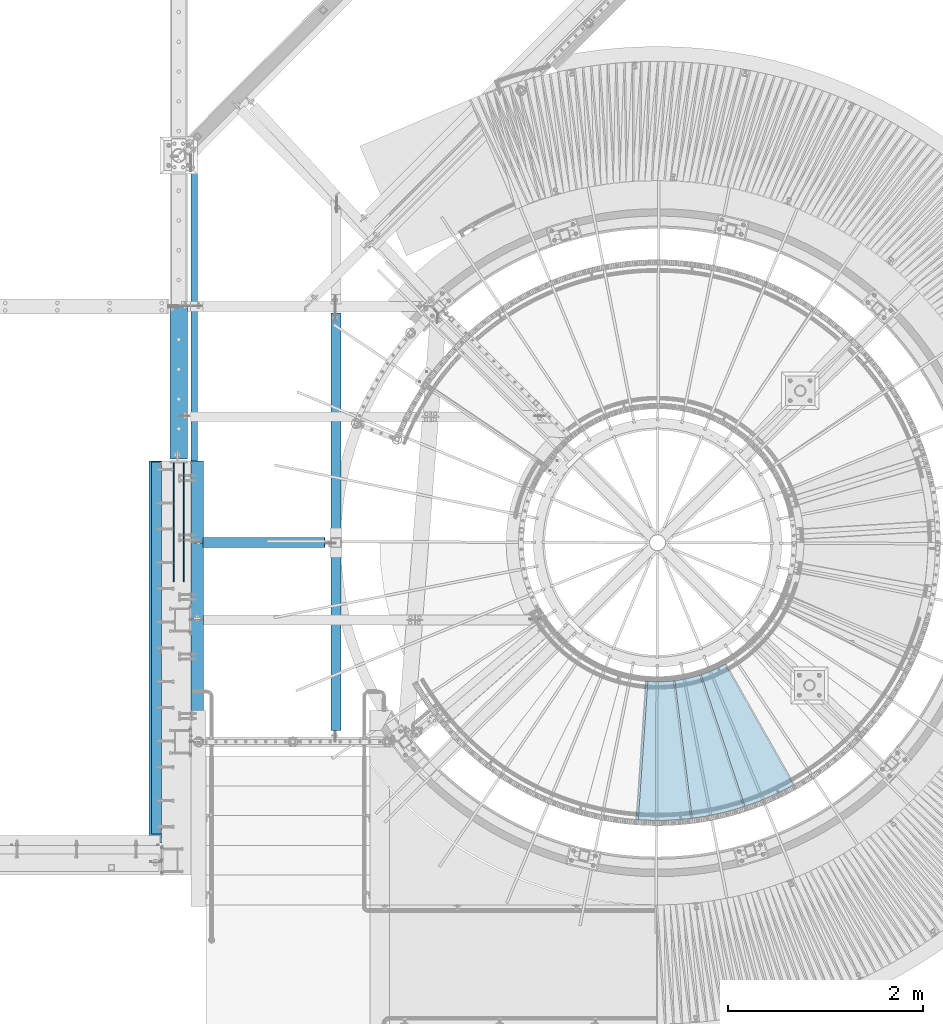
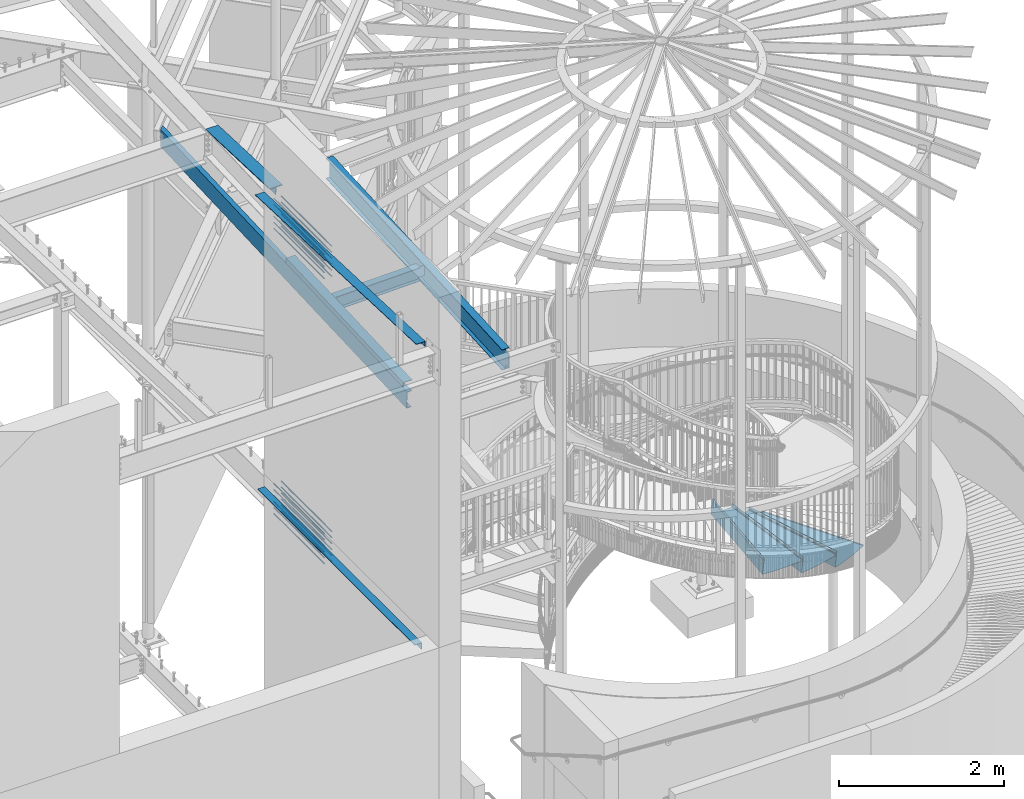
# One storey, part 341 of 975: 34 beams.
"""IFC2X3 building model written with IfcOpenShell, lengths in millimetres."""

from ifc_helpers import new_model, si_unit, frame, origin_with_axes, place, context, subcontext, project, spatial, faceted_brep, material, type_object, element, save


model = new_model("IFC2X3")

# Units and contexts
model_context = context("Model", 3, precision=1e-05, world=origin_with_axes())
body_context = subcontext(model_context, "Body", "Model", "MODEL_VIEW")
ifc_project = project(units=[si_unit("LENGTHUNIT", "METRE", prefix="MILLI"), si_unit("AREAUNIT", "SQUARE_METRE"), si_unit("VOLUMEUNIT", "CUBIC_METRE"), si_unit("MASSUNIT", "GRAM", prefix="KILO"), si_unit("TIMEUNIT", "SECOND"), si_unit("PLANEANGLEUNIT", "RADIAN"), si_unit("SOLIDANGLEUNIT", "STERADIAN"), si_unit("THERMODYNAMICTEMPERATUREUNIT", "DEGREE_CELSIUS"), si_unit("LUMINOUSINTENSITYUNIT", "LUMEN")], contexts=[model_context])

# Site, building, storey
site_placement = place(None, origin_with_axes())
site = spatial("IfcSite", under=ifc_project, at=site_placement, CompositionType="ELEMENT")
building_placement = place(site_placement, origin_with_axes())
building = spatial("IfcBuilding", under=site, at=building_placement, Name="Undefined", CompositionType="ELEMENT")
storey_placement = place(building_placement, origin_with_axes())
storey = spatial("IfcBuildingStorey", under=building, at=storey_placement, Name="Undefined", CompositionType="ELEMENT", Elevation=0.0)

# Beams
ifc_material_1 = material(Name="STEEL/A36")
beam_type_1 = type_object("IfcBeamType", Name="C10X15.3", PredefinedType="NOTDEFINED")
beam_1_placement = place(storey_placement, frame((29992.6373419842, 1312.79762171317, 6876.15207413472), z_axis=(-7.0905516622588e-09, -0.0430877640020049, 0.999071291046494), x_axis=(-8.50000000943246e-08, 0.999071290960394, 0.0430877659982918)))
element("IfcBeam", 1, at=beam_1_placement, inside=storey, type_object=beam_type_1, material=ifc_material_1, Name="BEAM", ObjectType="C10X15.3", context=body_context, shape_type="Brep", body=[
    faceted_brep([(-1.70985003933311e-10, -33.3375000000001, -126.999999999975), (-1.70985003933311e-10, 33.3375000000001, -126.999999999975), (5970.96165526552, 33.3374999961597, -127.000000000412), (6038.12023908904, -33.3375000038795, -127.0000000004), (-1.63709046319127e-10, -33.3375000000001, -121.44152749997), (6038.35996387556, -33.3375000038795, -121.441527500399), (-1.4915713109076e-10, 26.9875000000002, -111.391382499976), (5978.03087647182, 26.9874999961648, -111.391382500409), (1.52795109897852e-10, 26.9875000000002, 111.391382499978), (5978.10188780379, 26.9874999961648, -109.744850484867), (5978.68804457462, 26.9874999961685, -96.1536973187012), (5987.16476794745, 26.9874999962522, 100.395163735988), (5987.63901086143, 26.9874999962558, 111.391382499631), (1.70985003933311e-10, -33.3375000000001, 121.441527499974), (6048.83497990025, -33.3375000037777, 121.441527499643), (1.78260961547494e-10, -33.3375000000001, 126.999999999975), (6049.07470468678, -33.3375000037777, 126.999999999644), (1.78260961547494e-10, 33.3375000000001, 126.999999999975), (5981.91612086325, 33.3374999962653, 126.999999999633), (5981.25121124712, 33.337499996258, 111.582813192066), (5980.76871234526, 33.3374999962543, 100.395163737245), (5972.29198897244, 33.3374999961707, -96.1536973174443), (5971.71770683316, 33.337499996167, -109.469514695815)], [[[0, 1, 2, 3]], [[4, 0, 3, 5]], [[6, 4, 5, 7]], [[8, 6, 7, 9, 10, 11, 12]], [[13, 8, 12, 14]], [[15, 13, 14, 16]], [[0, 4, 6, 8, 13, 15, 17, 1]], [[1, 17, 18, 19, 20, 21, 22, 2]], [[21, 20, 19, 18, 16, 14, 12, 11, 10, 9, 7, 5, 3, 2, 22]], [[17, 15, 16, 18]]]),
])
beam_type_2 = type_object("IfcBeamType", PredefinedType="NOTDEFINED")
beam_2_placement = place(storey_placement, frame((35408.3134365946, 1319.64238191118, 3003.51695574218), z_axis=(0.314957553866778, -0.949105757680489, -2.58073669101578e-11), x_axis=(0.671119117250905, 0.222708622083281, 0.707106781264423)))
element("IfcBeam", 2, at=beam_2_placement, inside=storey, type_object=beam_type_2, material=ifc_material_1, Name="TREAD", context=body_context, shape_type="Brep", body=[
    faceted_brep([(25.4000001621371, 1.5874997143419, 653.28751700326), (1.61144271260127e-08, 1.58750000026703, 653.458911680114), (-1.96268956642598e-08, -1.58749999973588, 653.437487347819), (15.8745748038546, -1.5875001784334, 653.330368544412), (-120.373022221533, -103.76749224318, 653.560250726816), (-154.208562872085, -137.603032237963, 653.560249286144), (-49.0005534961238, -242.811041643061, 652.140399877677), (-46.7554894721361, -240.565977619684, 652.140399877557), (-149.718432901582, -137.603030988068, 653.529952160912), (-118.287540217565, -106.172138299769, 653.529952144057), (82.2634121742994, -374.075007349978, 638.193006315465), (84.508476198167, -371.829943326711, 638.193006315345), (212.601306559884, -504.412901568812, 612.134347567509), (214.846370562875, -502.167837565145, 612.134347570151), (261.055176792581, -530.596712595621, 601.111823144849), (259.197053542079, -528.103470062568, 601.754434690294), (248.701623596196, -536.023091227627, 602.134831213494), (248.362633442506, -540.174228440612, 601.571851715846), (250.921725105154, -538.24319290819, 601.479100122608), (25.4000001865188, 1.58749971376164, -768.618736200977), (-118.287540216395, -106.172138302336, -768.542582766611), (-149.718433278054, -137.603031368186, -768.542582749815), (-92.8426928760819, -194.478774201189, -768.783692225286), (-95.087756899542, -196.723838224048, -768.783692225159), (-154.208562871598, -137.603032235413, -768.533065523057), (-120.373022220361, -103.767492245748, -768.533065418116), (15.8745748282345, -1.58750017901184, -768.605275732323), (-1.58015609486029e-08, -1.58750000031432, -768.571627720263), (1.99397618416697e-08, 1.58749999968677, -768.564897939472), (-21.2434099455131, -266.078057151808, -776.330856581004), (-23.4884739689005, -268.323121174595, -776.330856580884), (49.7927349215133, -337.114201961485, -791.08236047571), (47.5476709198538, -339.35926596382, -791.082360478347), (66.437802308692, -335.979336534963, -793.502619428495), (56.3071310127107, -343.628597994977, -793.115412720523), (53.7487404151489, -345.560335457225, -793.01762786691), (54.0919957188744, -341.413461775162, -792.424099714608), (64.5845451579717, -333.490960101732, -792.825137753654)], [[[0, 1, 2, 3, 4, 5, 6, 7, 8, 9]], [[7, 6, 10, 11]], [[11, 10, 12, 13]], [[14, 15, 16, 13, 12, 17, 18]], [[19, 20, 21, 22, 23, 24, 25, 26, 27, 28]], [[29, 30, 23, 22]], [[31, 32, 30, 29]], [[33, 34, 35, 32, 31, 36, 37]], [[34, 33, 14, 18]], [[35, 34, 18, 17]], [[10, 6, 5, 24, 23, 30, 32, 35, 17, 12]], [[25, 24, 5, 4]], [[26, 25, 4, 3]], [[27, 26, 3, 2]], [[28, 27, 2, 1]], [[19, 28, 1, 0]], [[20, 19, 0, 9]], [[20, 9, 8, 21]], [[36, 31, 29, 22, 21, 8, 7, 11, 13, 16]], [[37, 36, 16, 15]], [[33, 37, 15, 14]]]),
])
beam_3_placement = place(storey_placement, frame((34992.0712427579, 1228.61472275559, 3181.31695574218), z_axis=(0.125233692150883, -0.992127271246113, 1.18870502774371e-10), x_axis=(0.701539921236418, 0.0885535930298356, 0.707106781238242)))
element("IfcBeam", 3, at=beam_3_placement, inside=storey, type_object=beam_type_2, material=ifc_material_1, Name="TREAD", context=body_context, shape_type="Brep", body=[
    faceted_brep([(25.4000001621371, 1.5874997143419, 653.28751700326), (1.61144271260127e-08, 1.58750000026703, 653.458911680114), (-1.96268956642598e-08, -1.58749999973588, 653.437487347819), (15.8745748038546, -1.5875001784334, 653.330368544412), (-120.373022221533, -103.76749224318, 653.560250726816), (-154.208562872085, -137.603032237963, 653.560249286144), (-49.0005534961238, -242.811041643061, 652.140399877677), (-46.7554894721361, -240.565977619684, 652.140399877557), (-149.718432901582, -137.603030988068, 653.529952160912), (-118.287540217565, -106.172138299769, 653.529952144057), (82.2634121742994, -374.075007349978, 638.193006315465), (84.508476198167, -371.829943326711, 638.193006315345), (212.601306559884, -504.412901568812, 612.134347567509), (214.846370562875, -502.167837565145, 612.134347570151), (261.055176792581, -530.596712595621, 601.111823144849), (259.197053542079, -528.103470062568, 601.754434690294), (248.701623596196, -536.023091227627, 602.134831213494), (248.362633442506, -540.174228440612, 601.571851715846), (250.921725105154, -538.24319290819, 601.479100122608), (25.4000001865188, 1.58749971376164, -768.618736200977), (-118.287540216395, -106.172138302336, -768.542582766611), (-149.718433278054, -137.603031368186, -768.542582749815), (-92.8426928760819, -194.478774201189, -768.783692225286), (-95.087756899542, -196.723838224048, -768.783692225159), (-154.208562871598, -137.603032235413, -768.533065523057), (-120.373022220361, -103.767492245748, -768.533065418116), (15.8745748282345, -1.58750017901184, -768.605275732323), (-1.58015609486029e-08, -1.58750000031432, -768.571627720263), (1.99397618416697e-08, 1.58749999968677, -768.564897939472), (-21.2434099455131, -266.078057151808, -776.330856581004), (-23.4884739689005, -268.323121174595, -776.330856580884), (49.7927349215133, -337.114201961485, -791.08236047571), (47.5476709198538, -339.35926596382, -791.082360478347), (66.437802308692, -335.979336534963, -793.502619428495), (56.3071310127107, -343.628597994977, -793.115412720523), (53.7487404151489, -345.560335457225, -793.01762786691), (54.0919957188744, -341.413461775162, -792.424099714608), (64.5845451579717, -333.490960101732, -792.825137753654)], [[[0, 1, 2, 3, 4, 5, 6, 7, 8, 9]], [[7, 6, 10, 11]], [[11, 10, 12, 13]], [[14, 15, 16, 13, 12, 17, 18]], [[19, 20, 21, 22, 23, 24, 25, 26, 27, 28]], [[29, 30, 23, 22]], [[31, 32, 30, 29]], [[33, 34, 35, 32, 31, 36, 37]], [[34, 33, 14, 18]], [[35, 34, 18, 17]], [[10, 6, 5, 24, 23, 30, 32, 35, 17, 12]], [[25, 24, 5, 4]], [[26, 25, 4, 3]], [[27, 26, 3, 2]], [[28, 27, 2, 1]], [[19, 28, 1, 0]], [[20, 19, 0, 9]], [[20, 9, 8, 21]], [[36, 31, 29, 22, 21, 8, 7, 11, 13, 16]], [[37, 36, 16, 15]], [[33, 37, 15, 14]]]),
])
beam_4_placement = place(storey_placement, frame((34566.0810090848, 1219.90154443776, 3359.11695574218), z_axis=(-0.0692297635944196, -0.997600741696126, 3.83573933504522e-10), x_axis=(0.705410249287495, -0.0489528350199457, 0.707106781288134)))
element("IfcBeam", 4, at=beam_4_placement, inside=storey, type_object=beam_type_2, material=ifc_material_1, Name="TREAD", context=body_context, shape_type="Brep", body=[
    faceted_brep([(25.4000001621371, 1.5874997143419, 653.28751700326), (1.61144271260127e-08, 1.58750000026703, 653.458911680114), (-1.96268956642598e-08, -1.58749999973588, 653.437487347819), (15.8745748038546, -1.5875001784334, 653.330368544412), (-120.373022221533, -103.76749224318, 653.560250726816), (-154.208562872085, -137.603032237963, 653.560249286144), (-49.0005534961238, -242.811041643061, 652.140399877677), (-46.7554894721361, -240.565977619684, 652.140399877557), (-149.718432901582, -137.603030988068, 653.529952160912), (-118.287540217565, -106.172138299769, 653.529952144057), (82.2634121742994, -374.075007349978, 638.193006315465), (84.508476198167, -371.829943326711, 638.193006315345), (212.601306559884, -504.412901568812, 612.134347567509), (214.846370562875, -502.167837565145, 612.134347570151), (261.055176792581, -530.596712595621, 601.111823144849), (259.197053542079, -528.103470062568, 601.754434690294), (248.701623596196, -536.023091227627, 602.134831213494), (248.362633442506, -540.174228440612, 601.571851715846), (250.921725105154, -538.24319290819, 601.479100122608), (25.4000001865188, 1.58749971376164, -768.618736200977), (-118.287540216395, -106.172138302336, -768.542582766611), (-149.718433278054, -137.603031368186, -768.542582749815), (-92.8426928760819, -194.478774201189, -768.783692225286), (-95.087756899542, -196.723838224048, -768.783692225159), (-154.208562871598, -137.603032235413, -768.533065523057), (-120.373022220361, -103.767492245748, -768.533065418116), (15.8745748282345, -1.58750017901184, -768.605275732323), (-1.58015609486029e-08, -1.58750000031432, -768.571627720263), (1.99397618416697e-08, 1.58749999968677, -768.564897939472), (-21.2434099455131, -266.078057151808, -776.330856581004), (-23.4884739689005, -268.323121174595, -776.330856580884), (49.7927349215133, -337.114201961485, -791.08236047571), (47.5476709198538, -339.35926596382, -791.082360478347), (66.437802308692, -335.979336534963, -793.502619428495), (56.3071310127107, -343.628597994977, -793.115412720523), (53.7487404151489, -345.560335457225, -793.01762786691), (54.0919957188744, -341.413461775162, -792.424099714608), (64.5845451579717, -333.490960101732, -792.825137753654)], [[[0, 1, 2, 3, 4, 5, 6, 7, 8, 9]], [[7, 6, 10, 11]], [[11, 10, 12, 13]], [[14, 15, 16, 13, 12, 17, 18]], [[19, 20, 21, 22, 23, 24, 25, 26, 27, 28]], [[29, 30, 23, 22]], [[31, 32, 30, 29]], [[33, 34, 35, 32, 31, 36, 37]], [[34, 33, 14, 18]], [[35, 34, 18, 17]], [[10, 6, 5, 24, 23, 30, 32, 35, 17, 12]], [[25, 24, 5, 4]], [[26, 25, 4, 3]], [[27, 26, 3, 2]], [[28, 27, 2, 1]], [[19, 28, 1, 0]], [[20, 19, 0, 9]], [[20, 9, 8, 21]], [[36, 31, 29, 22, 21, 8, 7, 11, 13, 16]], [[37, 36, 16, 15]], [[33, 37, 15, 14]]]),
])
beam_type_3 = type_object("IfcBeamType", Name="L4X4X5/16", PredefinedType="NOTDEFINED")
beam_5_placement = place(storey_placement, frame((29603.6999363074, 419.099996761458, 3886.2), z_axis=(0.0, 0.0, -1.0), x_axis=(0.0, 1.0, 0.0)))
element("IfcBeam", 5, at=beam_5_placement, inside=storey, type_object=beam_type_3, material=ifc_material_1, Name="LEDGER_ANGLE", ObjectType="L4X4X5/16", context=body_context, shape_type="Brep", body=[
    faceted_brep([(-1.90993887372315e-11, 50.8000000000002, -50.8), (2.00088834390044e-11, 50.8000000000002, 50.8), (3810.00075419025, 50.7999999947679, 50.8000000000002), (3810.00075419025, 50.7999999947679, -50.8000000000002), (2.00088834390044e-11, 42.8625000000002, 50.8), (3810.00075419025, 42.8624999947679, 50.8000000000002), (-1.63709046319127e-11, 42.8625000000002, -42.8625), (3810.00075419025, 42.8624999947679, -42.8625000000002), (-1.63709046319127e-11, -50.8000000000002, -42.8625), (3810.00075419025, -50.8000000052343, -42.8625000000002), (-1.90993887372315e-11, -50.8000000000002, -50.8), (3810.00075419025, -50.8000000052343, -50.8000000000002)], [[[0, 1, 2, 3]], [[1, 4, 5, 2]], [[4, 6, 7, 5]], [[6, 8, 9, 7]], [[8, 10, 11, 9]], [[10, 0, 3, 11]], [[5, 7, 9, 11, 3, 2]], [[10, 8, 6, 4, 1, 0]]]),
])
ifc_material_2 = material(Name="STEEL/A992")
beam_type_4 = type_object("IfcBeamType", Name="W8X10", PredefinedType="NOTDEFINED")
beam_6_placement = place(storey_placement, frame((29961.393845342, 3403.60003796743, 6993.45129694628), z_axis=(-0.0209368719931153, 9.99999883788405e-10, 0.99978079967118), x_axis=(0.99978079967118, -2.59999999524945e-08, 0.0209368719931138)))
element("IfcBeam", 6, at=beam_6_placement, inside=storey, type_object=beam_type_4, material=ifc_material_2, Name="BEAM", ObjectType="W8X10", context=body_context, shape_type="Brep", body=[
    faceted_brep([(1366.36293283311, -2.38125000024456, -95.2499999995944), (1366.3629328331, -50.8000000002444, -95.2499999995825), (1366.3629328331, -50.8000000002448, -100.012499999583), (1366.36293283312, 50.7999999997551, -100.012499999608), (1366.36293283312, 50.7999999997555, -95.2499999996062), (1366.36293283311, 2.38001982261312, -95.2499999995962), (1366.36293283308, 2.3743549506662, -87.3124998025069), (1366.36293283308, -2.38125000024456, -87.312499802505), (1367.32966275568, 2.3745989008612, -82.4524202844541), (1367.32966275568, -2.38125000024502, -82.4524202844523), (1370.08267665615, 2.37480724763464, -78.3322438162913), (1370.08267665615, -2.38125000024547, -78.3322438162886), (1374.2028531243, 2.37494827207865, -75.579229915802), (1374.2028531243, -2.38125000024593, -75.5792299157993), (1379.06293264233, 2.37500050449989, -74.6124999932026), (1379.06293264233, -2.38125000024684, -74.6124999932008), (1451.60602770409, -2.38125000026002, -74.6124999928106), (1451.60602790885, 2.38124999974025, -74.6124999928106), (120.656961117777, 2.38124999997763, 95.2500000000655), (120.656961117784, 50.7999999999779, 95.2500000000537), (1366.36293283312, 50.7999999997537, 95.2500000004484), (1366.36293283311, 2.38124999975344, 95.2500000004593), (120.65696111786, -2.38125000002083, -87.3124998085896), (120.65696111786, 2.37354101444362, -87.3124998085914), (120.656961117842, 2.36195093393553, -95.2499999999982), (120.656961117849, 50.7999999999797, -95.2500000000009), (120.656961117857, 50.7999999999793, -100.012500000002), (120.656961117838, -50.8000000000206, -100.012499999978), (120.656961117835, -50.8000000000202, -95.2499999999773), (120.656961117846, -2.38125000002037, -95.2499999999891), (119.690231195294, -2.38125000002083, -82.4524202905468), (119.690231195287, 2.37379156979932, -82.4524202905504), (116.937217294842, -2.38125000001992, -78.3322438224013), (116.937217294842, 2.37400408252415, -78.3322438224031), (112.817040826721, -2.38125000001946, -75.5792299219329), (112.817040826721, 2.37414619948322, -75.5792299219338), (107.956961308708, -2.38125000001855, -74.6124999993517), (107.956961308704, 2.37419628465796, -74.6124999993535), (31.7569611155486, -2.38125000000491, -74.61249999967), (31.7569611155232, 2.38124999999491, -74.6124999996691), (31.7569611158287, -2.38125000000628, 74.6125000009188), (31.7569611158033, 2.381249999994, 74.6125000009197), (107.956961308468, -2.38125000002037, 74.6125000008324), (107.956961308468, 2.38169990148799, 74.6125000008296), (112.817040826496, -2.38125000002083, 75.5792299234326), (112.817040826492, 2.38174931900858, 75.5792299234299), (116.937217294642, -2.38125000002174, 78.3322438239247), (116.937217294642, 2.38189030841568, 78.3322438239229), (119.690231195123, -2.38125000002219, 82.4524202920911), (119.690231195116, 2.38210140535011, 82.4524202920893), (120.656961117718, -2.38125000002265, 87.3124998101466), (120.656961117718, 2.38235047221769, 87.3124998101448), (120.656961117762, -50.800000000057, 100.087644163046), (120.65696111778, 50.799999999977, 100.012500000054), (120.656961117773, -2.38125000002219, 95.2500000000655), (120.656961117762, -50.8000000000229, 95.2500000000773), (1366.36293283311, -2.38125000024638, 95.2500000004611), (1366.3629328331, -50.8000000002467, 95.250000000472), (1366.3629328331, -50.8000000002494, 100.017505459706), (1366.36293283312, 50.7999999997533, 100.012500000449), (1366.36293283299, -2.38125000024638, 87.3124998162448), (1366.36293283299, 2.38293284286465, 87.3124998162421), (1367.32966275556, -2.38125000024638, 82.4524202981975), (1367.32966275556, 2.38269297448505, 82.4524202981947), (1370.08267665601, -2.38125000024729, 78.3322438300456), (1370.08267665601, 2.38249097509743, 78.3322438300438), (1374.20285312414, -2.3812500002482, 75.5792299295745), (1374.20285312413, 2.38235759727786, 75.5792299295726), (1379.06293264215, -2.38125000024866, 74.612500006996), (1379.06293264215, 2.38231314659106, 74.6125000069942), (1454.73101742629, -2.38125000026184, 74.6125000069069), (1454.73101763105, 2.38124999973797, 74.6125000069078)], [[[0, 1, 2, 3, 4, 5, 6, 7]], [[7, 6, 8, 9]], [[9, 8, 10, 11]], [[11, 10, 12, 13]], [[13, 12, 14, 15]], [[16, 15, 14, 17]], [[18, 19, 20, 21]], [[22, 23, 24, 25, 26, 27, 28, 29]], [[30, 31, 23, 22]], [[32, 33, 31, 30]], [[34, 35, 33, 32]], [[36, 37, 35, 34]], [[38, 39, 37, 36]], [[40, 41, 39, 38]], [[42, 43, 41, 40]], [[44, 45, 43, 42]], [[46, 47, 45, 44]], [[48, 49, 47, 46]], [[50, 51, 49, 48]], [[52, 53, 19, 18, 51, 50, 54, 55]], [[55, 54, 56, 57]], [[52, 55, 57, 58]], [[53, 52, 58, 59]], [[19, 53, 59, 20]], [[58, 57, 56, 60, 61, 21, 20, 59]], [[62, 63, 61, 60]], [[64, 65, 63, 62]], [[66, 67, 65, 64]], [[68, 69, 67, 66]], [[70, 71, 69, 68]], [[71, 70, 16, 17]], [[12, 10, 8, 6, 5, 24, 23, 31, 33, 35, 37, 39, 41, 43, 45, 47, 49, 51, 18, 21, 61, 63, 65, 67, 69, 71, 17, 14]], [[25, 24, 5, 4]], [[26, 25, 4, 3]], [[27, 26, 3, 2]], [[28, 27, 2, 1]], [[29, 28, 1, 0]], [[70, 68, 66, 64, 62, 60, 56, 54, 50, 48, 46, 44, 42, 40, 38, 36, 34, 32, 30, 22, 29, 0, 7, 9, 11, 13, 15, 16]]]),
])
beam_type_5 = type_object("IfcBeamType", Name="L5X3X5/16", PredefinedType="NOTDEFINED")
beam_7_placement = place(storey_placement, frame((30022.7998529182, 1400.27550760663, 7045.17827651895), z_axis=(1.0, 0.0, 0.0), x_axis=(-8.50000000943246e-08, 0.999071290960394, 0.0430877659982918)))
element("IfcBeam", 7, at=beam_7_placement, inside=storey, type_object=beam_type_5, material=ifc_material_1, Name="ANGLE", ObjectType="L5X3X5/16", context=body_context, shape_type="Brep", body=[
    faceted_brep([(5.0931703299284e-11, 38.0999999999999, -63.5000000000255), (-4.72937244921923e-11, 38.0999999999999, 63.5000000000182), (2845.80985187159, 38.0999999998394, 63.4999999961292), (2845.80985187158, 38.0999999998085, -63.5000000038708), (-3.63797880709171e-12, 30.1625000000404, 63.4999999999909), (2845.80985187159, 30.1624999998385, 63.4999999961183), (3.41060513164848e-12, 30.1624999999367, -55.5625000000091), (2845.80985187158, 30.1624999998094, -55.5625000038817), (2.27373675443232e-12, -38.1000000000313, -55.5624999999873), (2845.80985187157, -38.1000000002032, -55.5625000039472), (5.0931703299284e-11, -38.0999999999999, -63.5000000000255), (2845.80985187157, -38.100000000205, -63.5000000039472)], [[[0, 1, 2, 3]], [[1, 4, 5, 2]], [[4, 6, 7, 5]], [[6, 8, 9, 7]], [[8, 10, 11, 9]], [[10, 0, 3, 11]], [[5, 7, 9, 11, 3, 2]], [[10, 8, 6, 4, 1, 0]]]),
])
beam_8_placement = place(storey_placement, frame((29590.9996115184, 4240.27161969301, 8253.56240887337), z_axis=(-0.999999999999998, 6.90000001668524e-08, 0.0), x_axis=(9.19999984034803e-08, -0.999194283073837, 0.0401345820029601)))
element("IfcBeam", 8, at=beam_8_placement, inside=storey, type_object=beam_type_5, material=ifc_material_1, Name="LEDGER_ANGLE", ObjectType="L5X3X5/16", context=body_context, shape_type="Brep", body=[
    faceted_brep([(5.0931703299284e-11, 38.0999999999999, -63.5000000000255), (-4.72937244921923e-11, 38.0999999999999, 63.5000000000182), (3911.62308434797, 38.0999999993273, 63.4999999966894), (3911.62308434791, 38.0999999992455, -63.5000000033106), (-3.63797880709171e-12, 30.1625000000404, 63.4999999999909), (3911.62308434797, 30.1624999993346, 63.4999999966894), (3.41060513164848e-12, 30.1624999999367, -55.5625000000091), (3911.62308434791, 30.16249999926, -55.5625000033106), (2.27373675443232e-12, -38.1000000000313, -55.5624999999873), (3911.6230843479, -38.1000000006807, -55.5625000033215), (5.0931703299284e-11, -38.0999999999999, -63.5000000000255), (3911.6230843479, -38.1000000006861, -63.5000000033215)], [[[0, 1, 2, 3]], [[1, 4, 5, 2]], [[4, 6, 7, 5]], [[6, 8, 9, 7]], [[8, 10, 11, 9]], [[10, 0, 3, 11]], [[5, 7, 9, 11, 3, 2]], [[10, 8, 6, 4, 1, 0]]]),
])
ifc_material_3 = material(Name="STEEL/A496")
beam_type_6 = type_object("IfcBeamType", Name="#6 DBA", PredefinedType="NOTDEFINED")
for number, where, z_axis, x_axis, name in (
    (9, (29781.5, 4222.74843758235, 8070.10118873333), (-0.999999999999998, 6.90000001668524e-08, 0.0), (0.0, -1.0, 0.0), "ROD"),
    (10, (29883.1, 4222.74843758235, 8070.10118873333), (-0.999999999999998, 6.90000001668524e-08, 0.0), (0.0, -1.0, 0.0), "ROD"),
    (11, (29781.5, 4222.74843758235, 7981.20118873333), (-0.999999999999998, 6.90000001668524e-08, 0.0), (0.0, -1.0, 0.0), "ROD"),
    (12, (29883.1, 4222.74843758235, 7981.20118873333), (-0.999999999999998, 6.90000001668524e-08, 0.0), (0.0, -1.0, 0.0), "ROD"),
    (13, (29781.5, 4222.74843758235, 7892.30118873333), (-0.999999999999998, 6.90000001668524e-08, 0.0), (0.0, -1.0, 0.0), "ROD"),
    (14, (29883.1, 4222.74843758235, 7892.30118873333), (-0.999999999999998, 6.90000001668524e-08, 0.0), (0.0, -1.0, 0.0), "ROD"),
    (15, (29781.5, 4222.74843758235, 7803.40118873333), (-0.999999999999998, 6.90000001668524e-08, 0.0), (0.0, -1.0, 0.0), "ROD"),
    (16, (29883.1, 4222.74843758235, 7803.40118873333), (-0.999999999999998, 6.90000001668524e-08, 0.0), (0.0, -1.0, 0.0), "ROD"),
    (17, (29781.5, 4222.74843758235, 7714.50118873333), (-0.999999999999998, 6.90000001668524e-08, 0.0), (0.0, -1.0, 0.0), "ROD"),
    (18, (29883.1, 4222.74843758235, 7714.50118873333), (-0.999999999999998, 6.90000001668524e-08, 0.0), (0.0, -1.0, 0.0), "ROD"),
    (19, (29781.5, 4222.74843758235, 8159.00118873333), (-0.999999999999998, 6.90000001668524e-08, 0.0), (0.0, -1.0, 0.0), "ROD"),
    (20, (29883.1, 4222.74843758235, 8159.00118873333), (-0.999999999999998, 6.90000001668524e-08, 0.0), (0.0, -1.0, 0.0), "ROD"),
    (21, (29781.5, 4222.74960937501, 3849.6875), (-0.999999999999998, 6.90000001668524e-08, 0.0), (0.0, -1.0, 0.0), "ROD"),
    (22, (29883.1, 4222.74960937501, 3849.6875), (-0.999999999999998, 6.90000001668524e-08, 0.0), (0.0, -1.0, 0.0), "ROD"),
    (23, (29781.5, 4222.74960937501, 3760.7875), (-0.999999999999998, 6.90000001668524e-08, 0.0), (0.0, -1.0, 0.0), "ROD"),
    (24, (29883.1, 4222.74960937501, 3760.7875), (-0.999999999999998, 6.90000001668524e-08, 0.0), (0.0, -1.0, 0.0), "ROD"),
    (25, (29781.5, 4222.74960937501, 3671.8875), (-0.999999999999998, 6.90000001668524e-08, 0.0), (0.0, -1.0, 0.0), "ROD"),
    (26, (29883.1, 4222.74960937501, 3671.8875), (-0.999999999999998, 6.90000001668524e-08, 0.0), (0.0, -1.0, 0.0), "ROD"),
    (27, (29781.5, 4222.74960937501, 3582.9875), (-0.999999999999998, 6.90000001668524e-08, 0.0), (0.0, -1.0, 0.0), "ROD"),
    (28, (29883.1, 4222.74960937501, 3582.9875), (-0.999999999999998, 6.90000001668524e-08, 0.0), (0.0, -1.0, 0.0), "ROD"),
    (29, (29781.5, 4222.74960937501, 3494.0875), (-0.999999999999998, 6.90000001668524e-08, 0.0), (0.0, -1.0, 0.0), "ROD"),
    (30, (29883.1, 4222.74960937501, 3494.0875), (-0.999999999999998, 6.90000001668524e-08, 0.0), (0.0, -1.0, 0.0), "ROD"),
    (31, (29781.5, 4222.74960937501, 3938.5875), (-0.999999999999998, 6.90000001668524e-08, 0.0), (0.0, -1.0, 0.0), "ROD"),
    (32, (29883.1, 4222.74960937501, 3938.5875), (-0.999999999999998, 6.90000001668524e-08, 0.0), (0.0, -1.0, 0.0), "ROD"),
):
    element("IfcBeam", number, at=place(storey_placement, frame(where, z_axis=z_axis, x_axis=x_axis)), inside=storey, type_object=beam_type_6, material=ifc_material_3, Name=name, ObjectType="#6 DBA", context=body_context, shape_type="Brep", body=[
        faceted_brep([(0.0, -6.34999999998763, -3.63797880709171e-12), (0.0, -4.49012806052269, -4.49012806054634), (1219.19983372321, -4.49012806053543, -4.49012805836537), (1219.19983372321, -6.35000000000036, 2.16823536902666e-09), (0.0, 7.27595761418343e-12, -6.35000000000764), (1219.19983372321, 0.0, -6.34999999783395), (0.0, 4.49012806053724, -4.49012806053906), (1219.19983372321, 4.49012806053543, -4.49012805836537), (0.0, 6.34999999999491, 5.45696821063757e-12), (1219.19983372321, 6.35000000000036, 2.16823536902666e-09), (0.0, 4.49012806052633, 4.49012806054634), (1219.19983372321, 4.49012806053543, 4.49012806270184), (0.0, 0.0, 6.35000000000764), (1219.19983372321, 0.0, 6.35000000216678), (0.0, -4.49012806053361, 4.49012806053543), (1219.19983372321, -4.49012806053543, 4.49012806270184)], [[[0, 1, 2, 3]], [[1, 4, 5, 2]], [[4, 6, 7, 5]], [[6, 8, 9, 7]], [[8, 10, 11, 9]], [[10, 12, 13, 11]], [[12, 14, 15, 13]], [[14, 0, 3, 15]], [[5, 7, 9, 11, 13, 15, 3, 2]], [[14, 12, 10, 8, 6, 4, 1, 0]]]),
    ])
beam_type_7 = type_object("IfcBeamType", Name="W12X14", PredefinedType="NOTDEFINED")
beam_9_placement = place(storey_placement, frame((31442.0249427009, 1373.70251169687, 6859.83835198025), z_axis=(-4.00000135414302e-09, -0.0576533330145289, 0.998336663251589), x_axis=(6.89999998938881e-08, 0.998336663251586, 0.057653333014529)))
element("IfcBeam", 33, at=beam_9_placement, inside=storey, type_object=beam_type_7, material=ifc_material_2, Name="BEAM", ObjectType="W12X14", context=body_context, shape_type="Brep", body=[
    faceted_brep([(103.594179853707, -2.3812499999367, 127.338404918763), (103.594179118478, 2.38125000006403, 127.338404918368), (26.7284969858924, 2.38125000019136, 131.777351150226), (26.7284977211227, -2.38124999980937, 131.777351150628), (108.501910625053, -2.38124999994034, 128.023327061016), (108.501909889824, 2.38125000005675, 128.02332706062), (112.773954279477, -2.38124999994398, 130.534219866308), (112.773953544247, 2.38125000005311, 130.534219865913), (115.759930896765, -2.38124999994034, 134.488822666335), (115.759930161535, 2.38125000006039, 134.488822665939), (117.00525260488, -2.3812499999367, 139.285083033355), (117.00525186965, 2.38125000006039, 139.285083032958), (117.670961374077, -50.7999999999192, 150.812500000032), (117.670945689677, 50.8000000000829, 150.812500000013), (117.304237065105, 50.800000000072, 144.462500000013), (117.304244539701, 2.38125000007494, 144.462500000023), (117.304245274907, -2.38124999992579, 144.462500000024), (117.304252749503, -50.7999999999265, 144.462500000033), (14.2811431256637, -2.38125000017317, -83.7635344024657), (14.2811423904332, 2.38124999982756, -83.7635344028704), (91.1468245232302, 2.38124999970023, -88.2024806345589), (91.1468252584605, -2.3812500003005, -88.2024806341615), (95.9430848902512, 2.38124999968932, -89.4478023426691), (95.9430856254817, -2.38125000030777, -89.4478023422716), (99.8976876902771, 2.3812499996784, -92.4337789599513), (99.8976884255071, -2.38125000032232, -92.4337789595547), (102.408580495567, 2.38124999966749, -96.7058226143708), (102.408581230797, -2.3812500003296, -96.7058226139752), (103.093502637816, 2.38124999965657, -101.613553385713), (103.093503373046, -2.38125000034415, -101.613553385317), (4381.53170618247, 2.38124999297361, -144.462499998058), (4381.53170283031, 50.7999999929743, -144.462499998068), (100.61899464709, 50.7999999995845, -144.462499999938), (100.619002121687, 2.38124999958382, -144.462499999928), (4381.16499420573, 50.7999999929634, -150.812499998066), (4381.16500123977, -50.8000000070388, -150.812499998046), (100.252301706916, -50.8000000004249, -150.812499999916), (100.252286022518, 50.7999999995736, -150.812499999936), (4381.53170986434, -50.8000000070278, -144.462499998047), (100.61901033149, -50.8000000004176, -144.462499999918), (4381.53170651219, -2.38125000702712, -144.462499998057), (100.619002856894, -2.38125000041691, -144.462499999927), (4398.21694860069, 2.3812499934611, 144.462500001893), (4398.21694524854, 50.7999999934618, 144.462500001884), (4398.58365387311, 50.7999999934727, 150.812500001883), (4398.58366090714, -50.8000000065294, 150.812500001903), (4398.21695228257, -50.8000000065367, 144.462500001904), (4398.21694893041, -2.38125000653963, 144.462500001894)], [[[0, 1, 2, 3]], [[4, 5, 1, 0]], [[6, 7, 5, 4]], [[8, 9, 7, 6]], [[10, 11, 9, 8]], [[12, 13, 14, 15, 11, 10, 16, 17]], [[18, 19, 20, 21]], [[21, 20, 22, 23]], [[23, 22, 24, 25]], [[25, 24, 26, 27]], [[27, 26, 28, 29]], [[30, 31, 32, 33]], [[34, 35, 36, 37]], [[35, 38, 39, 36]], [[38, 40, 41, 39]], [[29, 28, 33, 32, 37, 36, 39, 41]], [[31, 34, 37, 32]], [[30, 42, 43, 44, 45, 46, 47, 40, 38, 35, 34, 31]], [[46, 45, 12, 17]], [[47, 46, 17, 16]], [[8, 6, 4, 0, 3, 18, 21, 23, 25, 27, 29, 41, 40, 47, 16, 10]], [[19, 18, 3, 2]], [[42, 30, 33, 28, 26, 24, 22, 20, 19, 2, 1, 5, 7, 9, 11, 15]], [[43, 42, 15, 14]], [[44, 43, 14, 13]], [[45, 44, 13, 12]]]),
])
beam_type_8 = type_object("IfcBeamType", Name="W16X36", PredefinedType="NOTDEFINED")
beam_10_placement = place(storey_placement, frame((29832.3, 4235.26371086133, 8090.1205125228), z_axis=(0.0, -0.0386177369991901, -0.999254056979035), x_axis=(0.0, 0.999254056979035, -0.03861773699919)))
element("IfcBeam", 34, at=beam_10_placement, inside=storey, type_object=beam_type_8, material=ifc_material_2, Name="BEAM", ObjectType="W16X36", context=body_context, shape_type="Brep", body=[
    faceted_brep([(1577.85879879023, -88.9000000000015, -201.612498747692), (1577.85882461252, 88.9000000000015, -201.612500000059), (1439.58385749518, 88.9000000000015, -190.500000000055), (1439.58385749518, 3.96875, -190.500000000055), (28.9775249808331, 3.96875, -77.1362845165168), (28.9775249808331, -3.96875, -77.1362845165168), (1439.58385749518, -3.96875, -190.500000000055), (1439.58385749518, -88.9000000000015, -190.500000000055), (19.8670245717212, -88.9000000000015, -190.500000000036), (18.9739660179821, -88.9000000000015, -201.612500000041), (19.8670245717212, -3.96875, -190.500000000036), (19.8670245717212, 3.96875, -190.500000000036), (19.8670245717212, 88.9000000000015, -190.500000000036), (18.9739660179821, 88.9000000000015, -201.612500000041)], [[[0, 1, 2, 3, 4, 5, 6, 7]], [[8, 9, 0, 7]], [[10, 8, 7, 6]], [[10, 6, 5]], [[11, 12, 13, 9, 8, 10, 5, 4]], [[11, 4, 3]], [[12, 11, 3, 2]], [[13, 12, 2, 1]], [[9, 13, 1, 0]]]),
])

save(model, "model.ifc")
